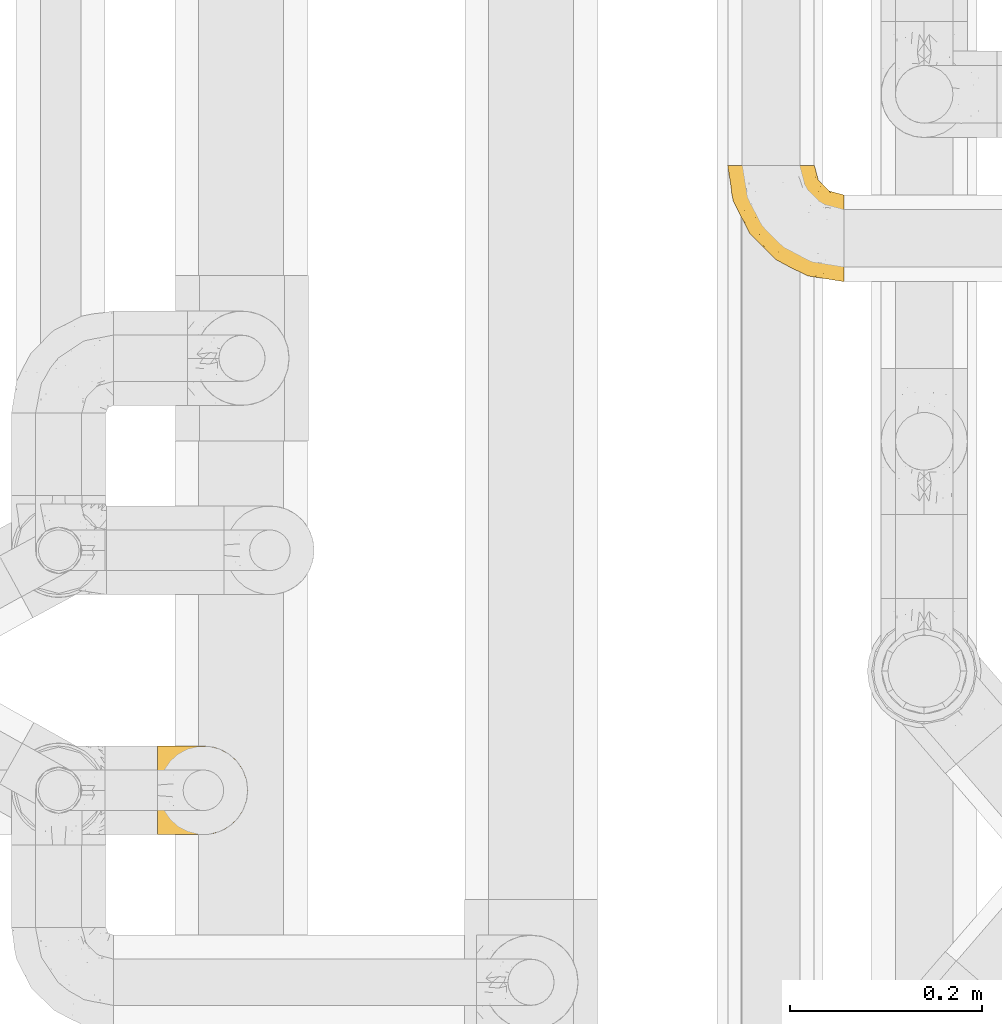
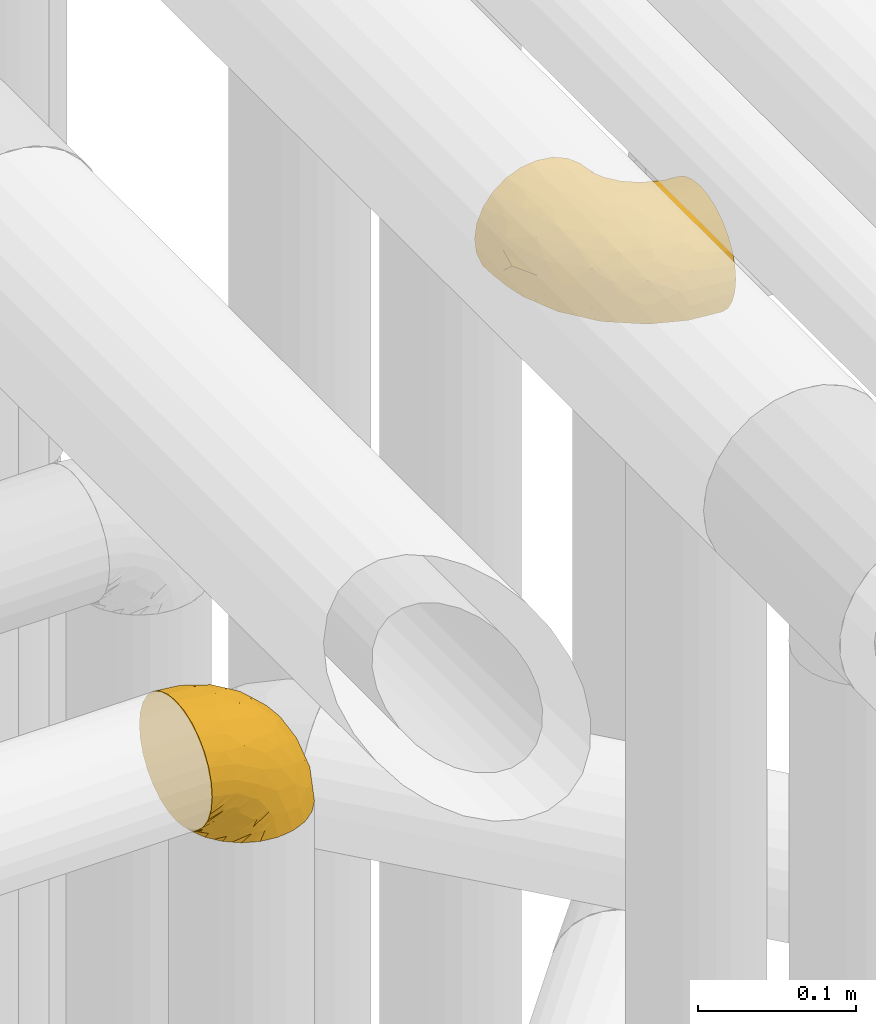
# One storey, part 201 of 827: 2 coverings.
"""IFC2X3 building model written with IfcOpenShell, lengths in millimetres."""

from ifc_helpers import new_model, entity, si_unit, converted_unit, derived_unit, direction, frame, origin, place, context, subcontext, project, spatial, faceted_brep, element, save


model = new_model("IFC2X3")

# Units and contexts
model_context = context("Model", 3, precision=0.01, world=origin(), true_north=direction((6.12303176911189e-17, 1.0)))
body_context = subcontext(model_context, "Body", "Model", "MODEL_VIEW")
ifc_project = project(units=[si_unit("LENGTHUNIT", "METRE", prefix="MILLI"), si_unit("AREAUNIT", "SQUARE_METRE"), si_unit("VOLUMEUNIT", "CUBIC_METRE"), converted_unit("PLANEANGLEUNIT", "DEGREE", entity("IfcRatioMeasure", 0.0174532925199433), si_unit("PLANEANGLEUNIT", "RADIAN"), dimensions=[0, 0, 0, 0, 0, 0, 0]), si_unit("MASSUNIT", "GRAM", prefix="KILO"), derived_unit("MASSDENSITYUNIT", [(si_unit("MASSUNIT", "GRAM", prefix="KILO"), 1), (si_unit("LENGTHUNIT", "METRE"), -3)]), derived_unit("MOMENTOFINERTIAUNIT", [(si_unit("LENGTHUNIT", "METRE"), 4)]), si_unit("TIMEUNIT", "SECOND"), si_unit("FREQUENCYUNIT", "HERTZ"), si_unit("THERMODYNAMICTEMPERATUREUNIT", "DEGREE_CELSIUS"), derived_unit("THERMALTRANSMITTANCEUNIT", [(si_unit("MASSUNIT", "GRAM", prefix="KILO"), 1), (si_unit("THERMODYNAMICTEMPERATUREUNIT", "KELVIN"), -1), (si_unit("TIMEUNIT", "SECOND"), -3)]), derived_unit("VOLUMETRICFLOWRATEUNIT", [(si_unit("LENGTHUNIT", "METRE"), 3), (si_unit("TIMEUNIT", "SECOND"), -1)]), derived_unit("MASSFLOWRATEUNIT", [(si_unit("MASSUNIT", "GRAM", prefix="KILO"), 1), (si_unit("TIMEUNIT", "SECOND"), -1)]), derived_unit("ROTATIONALFREQUENCYUNIT", [(si_unit("TIMEUNIT", "SECOND"), -1)]), si_unit("ELECTRICCURRENTUNIT", "AMPERE"), si_unit("ELECTRICVOLTAGEUNIT", "VOLT"), si_unit("POWERUNIT", "WATT"), si_unit("FORCEUNIT", "NEWTON", prefix="KILO"), si_unit("ILLUMINANCEUNIT", "LUX"), si_unit("LUMINOUSFLUXUNIT", "LUMEN"), si_unit("LUMINOUSINTENSITYUNIT", "CANDELA"), derived_unit("USERDEFINED", [(si_unit("MASSUNIT", "GRAM", prefix="KILO"), -1), (si_unit("LENGTHUNIT", "METRE"), -2), (si_unit("TIMEUNIT", "SECOND"), 3), (si_unit("LUMINOUSFLUXUNIT", "LUMEN"), 1)]), derived_unit("LINEARVELOCITYUNIT", [(si_unit("LENGTHUNIT", "METRE"), 1), (si_unit("TIMEUNIT", "SECOND"), -1)]), si_unit("PRESSUREUNIT", "PASCAL"), derived_unit("USERDEFINED", [(si_unit("LENGTHUNIT", "METRE"), -2), (si_unit("MASSUNIT", "GRAM", prefix="KILO"), 1), (si_unit("TIMEUNIT", "SECOND"), -2)]), derived_unit("LINEARFORCEUNIT", [(si_unit("MASSUNIT", "GRAM", prefix="KILO"), 1), (si_unit("LENGTHUNIT", "METRE"), 1), (si_unit("TIMEUNIT", "SECOND"), -2), (si_unit("LENGTHUNIT", "METRE"), -1)]), derived_unit("PLANARFORCEUNIT", [(si_unit("MASSUNIT", "GRAM", prefix="KILO"), 1), (si_unit("LENGTHUNIT", "METRE"), 1), (si_unit("TIMEUNIT", "SECOND"), -2), (si_unit("LENGTHUNIT", "METRE"), -2)])], contexts=[model_context])

# Site, building, storey
site_placement = place(None, origin())
site = spatial("IfcSite", under=ifc_project, at=site_placement, CompositionType="ELEMENT")
building_placement = place(site_placement, origin())
building = spatial("IfcBuilding", under=site, at=building_placement, CompositionType="ELEMENT")
storey_placement = place(building_placement, frame((0.0, 0.0, 28200.0)))
storey = spatial("IfcBuildingStorey", under=building, at=storey_placement, Name="08", CompositionType="ELEMENT", Elevation=28200.0)

# Coverings
covering_1_placement = place(storey_placement, frame((35829.19, 10308.37, 3350.4)))
element("IfcCovering", 1, at=covering_1_placement, inside=storey, Name=":ADSK_", ObjectType=":ADSK_", PredefinedType="INSULATION", context=body_context, shape_type="Brep", body=[
    faceted_brep([(1.6, 11.68, 78.41), (1.6, 19.0, 85.72), (1.6, 27.76, 91.22), (1.6, 37.52, 94.64), (1.6, 47.8, 95.8), (1.6, 58.08, 94.64), (1.6, 67.85, 91.22), (1.6, 76.61, 85.71), (1.6, 83.92, 78.39), (1.6, 89.42, 69.63), (1.6, 92.84, 59.87), (1.6, 94.0, 49.6), (1.6, 93.53, 45.45), (1.6, 93.18, 42.38), (1.6, 92.84, 39.31), (1.6, 91.13, 34.43), (1.6, 89.42, 29.54), (1.6, 86.66, 25.16), (1.6, 83.91, 20.78), (1.6, 80.25, 17.13), (1.6, 76.59, 13.47), (1.6, 67.83, 7.97), (1.6, 62.95, 6.26), (1.6, 58.07, 4.55), (1.6, 47.8, 3.4), (1.6, 37.51, 4.55), (1.6, 32.63, 6.26), (1.6, 27.74, 7.97), (1.6, 18.98, 13.48), (1.6, 15.33, 17.14), (1.6, 11.67, 20.8), (1.6, 8.92, 25.18), (1.6, 6.17, 29.56), (1.6, 4.46, 34.44), (1.6, 2.75, 39.32), (1.6, 2.41, 42.39), (1.6, 2.06, 45.45), (1.6, 1.6, 49.6), (1.6, 2.75, 59.88), (1.6, 6.17, 69.65), (3.4, 47.8, 1.6), (4.97, 59.75, 1.6), (9.58, 70.9, 1.6), (13.26, 75.68, 1.6), (16.93, 80.46, 1.6), (21.71, 84.13, 1.6), (26.5, 87.81, 1.6), (32.07, 90.11, 1.6), (37.64, 92.42, 1.6), (41.25, 92.9, 1.6), (43.34, 93.17, 1.6), (45.42, 93.45, 1.6), (49.6, 94.0, 1.6), (61.55, 92.42, 1.6), (72.7, 87.81, 1.6), (82.26, 80.46, 1.6), (89.61, 70.9, 1.6), (94.22, 59.75, 1.6), (95.8, 47.8, 1.6), (94.22, 35.84, 1.6), (89.61, 24.7, 1.6), (82.26, 15.13, 1.6), (72.7, 7.78, 1.6), (61.55, 3.17, 1.6), (49.6, 1.6, 1.6), (45.42, 2.14, 1.6), (41.25, 2.69, 1.6), (37.64, 3.17, 1.6), (32.07, 5.48, 1.6), (26.5, 7.78, 1.6), (21.71, 11.46, 1.6), (16.93, 15.13, 1.6), (13.26, 19.91, 1.6), (9.58, 24.7, 1.6), (4.97, 35.84, 1.6), (81.55, 23.61, 36.81), (90.4, 31.99, 23.28), (83.0, 35.87, 45.8), (91.18, 47.8, 30.7), (93.13, 40.43, 21.2), (94.0, 47.8, 12.96), (66.19, 31.83, 66.19), (70.92, 23.37, 54.51), (85.95, 21.41, 17.98), (49.74, 3.07, 36.69), (35.54, 1.6, 35.54), (38.14, 1.6, 31.64), (40.74, 1.6, 27.75), (43.34, 1.6, 23.86), (45.94, 1.6, 19.96), (77.59, 13.45, 22.8), (71.17, 15.25, 42.67), (65.81, 8.07, 33.21), (59.03, 16.0, 59.45), (45.85, 17.34, 71.5), (45.79, 10.58, 62.66), (41.42, 5.34, 54.5), (34.51, 2.39, 47.57), (56.04, 8.36, 48.81), (15.15, 10.04, 74.98), (56.51, 2.59, 18.7), (68.39, 6.28, 15.75), (23.33, 34.28, 91.17), (42.86, 38.73, 85.28), (39.42, 27.25, 82.58), (53.58, 29.88, 75.78), (59.17, 38.6, 74.98), (59.06, 23.44, 67.27), (22.63, 25.25, 87.38), (20.55, 17.23, 82.04), (12.96, 47.8, 94.0), (56.96, 47.8, 77.8), (67.38, 47.8, 67.38), (18.72, 2.53, 56.2), (5.33, 1.6, 48.85), (9.07, 1.6, 48.11), (11.79, 1.6, 47.57), (14.51, 1.6, 47.03), (17.24, 1.6, 46.48), (19.96, 1.6, 45.94), (21.03, 5.71, 65.78), (46.48, 1.6, 17.24), (47.03, 1.6, 14.51), (47.57, 1.6, 11.79), (48.11, 1.6, 9.07), (48.48, 1.6, 7.2), (48.85, 1.6, 5.33), (30.7, 47.8, 91.18), (23.86, 1.6, 43.34), (27.75, 1.6, 40.74), (31.64, 1.6, 38.14), (31.26, 11.89, 72.73), (77.8, 47.8, 56.96), (72.75, 39.69, 62.23), (43.83, 47.8, 84.49), (84.49, 47.8, 43.83), (14.58, 13.84, 12.05), (16.17, 9.16, 18.95), (10.82, 15.79, 13.02), (4.64, 25.75, 8.34), (7.71, 16.09, 14.63), (25.13, 7.51, 11.09), (32.66, 3.99, 13.66), (34.94, 2.66, 20.08), (36.76, 3.16, 9.61), (40.48, 2.35, 9.48), (39.25, 2.23, 16.1), (3.69, 38.35, 3.42), (13.99, 6.18, 26.63), (21.85, 2.7, 33.72), (17.93, 2.93, 34.77), (15.11, 16.01, 6.75), (21.14, 9.08, 13.31), (7.21, 11.68, 19.94), (12.7, 9.3, 21.11), (10.45, 21.65, 6.04), (32.27, 4.65, 8.67), (25.68, 3.65, 26.11), (22.18, 3.61, 29.3), (18.79, 12.8, 6.32), (10.12, 2.43, 39.92), (9.47, 6.83, 27.05), (11.29, 3.7, 34.4), (2.87, 47.8, 2.87), (31.16, 3.37, 20.92), (6.31, 7.03, 27.43), (25.62, 7.87, 7.54), (21.18, 7.26, 18.45), (28.81, 3.41, 23.88), (7.45, 23.81, 7.77), (21.17, 88.32, 18.43), (16.17, 86.42, 18.93), (25.69, 91.93, 26.08), (48.11, 94.0, 9.07), (48.85, 94.0, 5.33), (47.03, 94.0, 14.51), (47.57, 94.0, 11.79), (3.69, 57.24, 3.42), (7.44, 71.76, 7.76), (14.51, 94.0, 47.03), (11.79, 94.0, 47.57), (5.33, 94.0, 48.85), (9.07, 94.0, 48.11), (7.71, 79.49, 14.62), (9.47, 88.75, 27.03), (34.94, 92.93, 20.08), (31.16, 92.22, 20.92), (40.74, 94.0, 27.75), (38.14, 94.0, 31.64), (18.79, 82.79, 6.33), (36.76, 92.43, 9.61), (40.48, 93.24, 9.48), (4.63, 69.82, 8.33), (21.14, 86.5, 13.3), (15.11, 79.57, 6.74), (14.58, 81.74, 12.04), (43.34, 94.0, 23.86), (45.94, 94.0, 19.96), (39.25, 93.36, 16.1), (7.21, 83.9, 19.93), (12.69, 86.28, 21.1), (10.14, 93.16, 39.92), (21.81, 92.88, 33.68), (22.19, 91.98, 29.28), (14.0, 89.41, 26.62), (6.66, 88.82, 27.87), (17.92, 92.66, 34.75), (10.45, 73.93, 6.04), (31.64, 94.0, 38.14), (10.64, 79.5, 12.79), (11.31, 91.89, 34.41), (19.96, 94.0, 45.94), (23.86, 94.0, 43.34), (27.75, 94.0, 40.74), (32.66, 91.6, 13.66), (46.48, 94.0, 17.24), (32.27, 90.94, 8.67), (25.13, 88.08, 11.09), (35.54, 94.0, 35.54), (28.77, 92.16, 23.83), (23.36, 86.13, 6.03), (17.24, 94.0, 46.48), (47.58, 93.2, 34.52), (93.13, 55.16, 21.2), (77.44, 82.02, 23.82), (66.78, 84.29, 41.32), (71.68, 76.94, 47.62), (74.96, 68.33, 52.66), (81.55, 71.98, 36.81), (36.7, 92.52, 49.75), (56.9, 92.9, 19.07), (83.0, 59.72, 45.8), (90.4, 63.6, 23.28), (67.83, 88.89, 21.35), (85.95, 74.18, 17.98), (39.41, 68.35, 82.57), (23.33, 61.33, 91.17), (42.87, 56.86, 85.27), (53.92, 68.62, 73.89), (66.19, 63.76, 66.19), (64.12, 72.19, 62.43), (33.13, 88.69, 63.53), (23.1, 92.19, 58.45), (16.98, 89.75, 67.16), (55.72, 59.86, 76.72), (72.75, 55.9, 62.22), (23.77, 77.99, 81.54), (18.41, 85.21, 74.8), (43.7, 74.99, 75.83), (54.53, 90.23, 41.45), (17.73, 70.75, 88.2), (38.98, 81.72, 71.6), (50.28, 86.53, 56.23), (59.02, 79.6, 59.44)], [[[0, 1, 2, 3, 4, 5, 6, 7, 8, 9, 10, 11, 12, 13, 14, 15, 16, 17, 18, 19, 20, 21, 22, 23, 24, 25, 26, 27, 28, 29, 30, 31, 32, 33, 34, 35, 36, 37, 38, 39]], [[40, 41, 42, 43, 44, 45, 46, 47, 48, 49, 50, 51, 52, 53, 54, 55, 56, 57, 58, 59, 60, 61, 62, 63, 64, 65, 66, 67, 68, 69, 70, 71, 72, 73, 74]], [[75, 76, 77]], [[78, 79, 80]], [[77, 81, 82]], [[76, 75, 83]], [[84, 85, 86, 87, 88, 89]], [[90, 91, 92]], [[76, 60, 59]], [[93, 94, 95]], [[90, 62, 61]], [[83, 61, 60]], [[96, 97, 84]], [[98, 93, 95]], [[0, 39, 99]], [[100, 84, 89]], [[62, 101, 63]], [[2, 102, 3]], [[92, 84, 100]], [[103, 102, 104]], [[103, 105, 106]], [[93, 107, 94]], [[1, 108, 2]], [[92, 101, 90]], [[108, 1, 109]], [[102, 110, 3]], [[93, 82, 107]], [[102, 108, 104]], [[111, 106, 112]], [[109, 0, 99]], [[113, 37, 114, 115, 116, 117, 118, 119]], [[120, 38, 113]], [[100, 89, 121, 122, 123, 124, 125, 126, 64]], [[127, 102, 103]], [[97, 119, 128, 129, 130, 85]], [[99, 120, 131]], [[132, 133, 77]], [[59, 80, 79]], [[1, 0, 109]], [[98, 84, 92]], [[94, 109, 131]], [[120, 39, 38]], [[93, 91, 82]], [[104, 94, 105]], [[97, 113, 119]], [[95, 120, 96]], [[83, 90, 61]], [[91, 93, 98]], [[64, 63, 100]], [[100, 63, 101]], [[77, 76, 79]], [[133, 106, 81]], [[84, 97, 85]], [[113, 96, 120]], [[113, 97, 96]], [[37, 113, 38]], [[110, 102, 127]], [[110, 4, 3]], [[103, 111, 134, 127]], [[90, 75, 91]], [[82, 81, 107]], [[91, 75, 82]], [[77, 82, 75]], [[76, 83, 60]], [[90, 83, 75]], [[105, 107, 81]], [[94, 131, 95]], [[105, 94, 107]], [[109, 94, 104]], [[120, 95, 131]], [[98, 95, 96]], [[84, 98, 96]], [[98, 92, 91]], [[106, 105, 81]], [[103, 104, 105]], [[112, 106, 133]], [[103, 106, 111]], [[112, 133, 132]], [[81, 77, 133]], [[77, 78, 135, 132]], [[120, 99, 39]], [[109, 99, 131]], [[59, 58, 80]], [[59, 79, 76]], [[90, 101, 62]], [[100, 101, 92]], [[2, 108, 102]], [[109, 104, 108]], [[78, 77, 79]], [[136, 137, 138]], [[27, 139, 140]], [[141, 142, 143]], [[144, 145, 121]], [[146, 89, 88]], [[147, 139, 25]], [[148, 149, 150]], [[136, 151, 152]], [[147, 40, 74]], [[24, 147, 25]], [[153, 140, 154]], [[33, 116, 34]], [[73, 151, 155]], [[114, 37, 36, 35, 34, 116, 115]], [[146, 156, 144]], [[157, 85, 130]], [[158, 149, 148]], [[151, 159, 152]], [[117, 33, 160]], [[29, 153, 161]], [[155, 74, 73]], [[162, 128, 119]], [[66, 65, 64, 126, 125, 124, 123, 122, 67]], [[163, 147, 24]], [[27, 140, 28]], [[149, 129, 150]], [[139, 27, 26, 25]], [[68, 144, 69]], [[129, 128, 150]], [[164, 87, 86]], [[130, 129, 149]], [[122, 145, 67]], [[153, 154, 148]], [[162, 119, 160]], [[165, 30, 161]], [[150, 161, 148]], [[128, 162, 150]], [[30, 165, 31]], [[145, 144, 68]], [[89, 146, 144]], [[87, 164, 143]], [[166, 156, 142]], [[88, 87, 143]], [[162, 161, 150]], [[161, 30, 29]], [[161, 153, 148]], [[28, 140, 153]], [[29, 28, 153]], [[140, 137, 154]], [[158, 148, 154]], [[157, 130, 158]], [[154, 137, 158]], [[158, 137, 157]], [[167, 137, 136]], [[168, 85, 157]], [[152, 168, 167]], [[167, 168, 157]], [[164, 152, 141]], [[151, 73, 72]], [[159, 72, 71]], [[88, 142, 146]], [[144, 156, 69]], [[146, 142, 156]], [[70, 166, 71]], [[142, 141, 166]], [[70, 69, 156]], [[141, 159, 71]], [[167, 136, 152]], [[138, 137, 140]], [[155, 136, 169]], [[136, 155, 151]], [[74, 155, 169]], [[152, 159, 141]], [[151, 72, 159]], [[168, 152, 164]], [[137, 167, 157]], [[164, 86, 168]], [[85, 168, 86]], [[116, 33, 117]], [[130, 149, 158]], [[67, 145, 68]], [[121, 89, 144]], [[145, 122, 121]], [[40, 147, 163]], [[169, 147, 74]], [[160, 33, 32]], [[162, 160, 32]], [[160, 119, 118, 117]], [[139, 147, 169]], [[139, 169, 138]], [[162, 32, 31]], [[141, 143, 164]], [[88, 143, 142]], [[71, 166, 141]], [[156, 166, 70]], [[139, 138, 140]], [[169, 136, 138]], [[161, 162, 165]], [[162, 31, 165]], [[170, 171, 172]], [[173, 174, 52, 51, 50, 49, 48, 175, 176]], [[177, 178, 41]], [[179, 15, 180]], [[12, 11, 181, 182, 180, 14, 13]], [[183, 21, 20]], [[19, 18, 184]], [[185, 186, 187]], [[186, 188, 187]], [[43, 189, 44]], [[190, 191, 47]], [[23, 22, 21, 192]], [[193, 194, 195]], [[40, 163, 177]], [[196, 197, 198]], [[24, 23, 177]], [[199, 200, 183]], [[201, 15, 179]], [[178, 177, 192]], [[47, 46, 190]], [[202, 203, 204]], [[203, 172, 171]], [[205, 206, 184]], [[207, 41, 178]], [[16, 15, 201]], [[14, 180, 15]], [[204, 203, 200]], [[208, 203, 202]], [[163, 24, 177]], [[48, 47, 191]], [[198, 197, 190]], [[199, 184, 204]], [[171, 195, 209]], [[210, 211, 212]], [[206, 212, 213]], [[205, 17, 210]], [[184, 206, 204]], [[210, 212, 206]], [[185, 196, 214]], [[190, 215, 191]], [[216, 45, 214]], [[186, 217, 193]], [[190, 216, 198]], [[199, 20, 19]], [[196, 185, 187]], [[199, 183, 20]], [[184, 199, 19]], [[199, 204, 200]], [[206, 202, 204]], [[171, 183, 200]], [[203, 208, 172]], [[172, 208, 218]], [[171, 200, 203]], [[218, 188, 219]], [[195, 170, 193]], [[217, 186, 185]], [[193, 219, 186]], [[193, 170, 219]], [[207, 194, 42]], [[217, 220, 189]], [[216, 190, 46]], [[214, 196, 198]], [[44, 220, 45]], [[214, 198, 216]], [[216, 46, 45]], [[214, 45, 220]], [[42, 194, 43]], [[189, 193, 217]], [[207, 195, 194]], [[209, 195, 178]], [[41, 207, 42]], [[195, 207, 178]], [[43, 194, 189]], [[193, 189, 194]], [[171, 170, 195]], [[170, 172, 219]], [[218, 219, 172]], [[188, 186, 219]], [[206, 213, 202]], [[208, 202, 213]], [[201, 210, 16]], [[215, 190, 197]], [[215, 175, 191]], [[175, 48, 191]], [[201, 179, 221, 211]], [[210, 201, 211]], [[23, 192, 177]], [[40, 177, 41]], [[192, 183, 209]], [[21, 183, 192]], [[205, 18, 17]], [[17, 16, 210]], [[217, 185, 214]], [[189, 220, 44]], [[214, 220, 217]], [[192, 209, 178]], [[171, 209, 183]], [[206, 205, 210]], [[18, 205, 184]], [[222, 197, 196, 187, 188, 218]], [[57, 223, 80]], [[224, 225, 226]], [[226, 227, 228]], [[229, 218, 208, 213, 212, 211]], [[230, 52, 174, 173, 176, 175, 215, 197]], [[231, 232, 228]], [[231, 78, 223]], [[223, 57, 232]], [[224, 233, 225]], [[233, 54, 53]], [[234, 232, 56]], [[56, 55, 234]], [[234, 224, 228]], [[235, 236, 237]], [[224, 55, 54]], [[238, 239, 240]], [[52, 230, 53]], [[241, 242, 243]], [[239, 244, 245]], [[11, 10, 242]], [[236, 6, 5]], [[7, 246, 8]], [[8, 247, 9]], [[238, 248, 235]], [[222, 229, 249]], [[242, 211, 221, 179, 180, 182, 181, 11]], [[233, 53, 230]], [[111, 112, 244]], [[250, 6, 236]], [[247, 251, 241]], [[6, 250, 7]], [[127, 236, 110]], [[249, 229, 252]], [[247, 8, 246]], [[235, 246, 250]], [[236, 5, 110]], [[235, 244, 238]], [[237, 236, 127]], [[243, 9, 247]], [[252, 229, 241]], [[56, 232, 57]], [[222, 230, 197]], [[225, 249, 252]], [[249, 233, 230]], [[54, 233, 224]], [[231, 228, 227]], [[245, 132, 231]], [[249, 225, 233]], [[226, 225, 253]], [[235, 250, 236]], [[246, 7, 250]], [[251, 247, 246]], [[243, 247, 241]], [[248, 246, 235]], [[252, 251, 253]], [[229, 222, 218]], [[230, 222, 249]], [[5, 4, 110]], [[237, 127, 134, 111]], [[238, 244, 239]], [[224, 234, 55]], [[232, 234, 228]], [[242, 241, 229]], [[10, 9, 243]], [[211, 242, 229]], [[10, 243, 242]], [[80, 223, 78]], [[80, 58, 57]], [[231, 223, 232]], [[227, 240, 239]], [[224, 226, 228]], [[240, 226, 253]], [[227, 239, 245]], [[226, 240, 227]], [[251, 248, 253]], [[240, 253, 248]], [[244, 235, 237]], [[237, 111, 244]], [[132, 245, 112]], [[112, 245, 244]], [[135, 78, 231, 132]], [[227, 245, 231]], [[248, 238, 240]], [[246, 248, 251]], [[251, 252, 241]], [[225, 252, 253]]]),
])
covering_2_placement = place(storey_placement, frame((36423.29, 10884.43, 3153.25)))
element("IfcCovering", 2, at=covering_2_placement, inside=storey, Name=":ADSK_", ObjectType=":ADSK_", PredefinedType="INSULATION", context=body_context, shape_type="Brep", body=[
    faceted_brep([(122.75, 36.69, 90.76), (122.75, 27.15, 87.42), (122.75, 18.59, 82.04), (122.75, 11.44, 74.89), (122.75, 6.06, 66.33), (122.75, 2.73, 56.79), (122.75, 1.6, 46.75), (122.75, 2.73, 36.69), (122.75, 6.07, 27.15), (122.75, 11.45, 18.59), (122.75, 18.6, 11.44), (122.75, 27.16, 6.06), (122.75, 36.7, 2.73), (122.75, 46.75, 1.6), (122.75, 56.8, 2.73), (122.75, 66.34, 6.07), (122.75, 74.9, 11.45), (122.75, 82.05, 18.6), (122.75, 87.43, 27.16), (122.75, 90.76, 36.7), (122.75, 91.9, 46.75), (122.75, 90.76, 56.8), (122.75, 87.42, 66.34), (122.75, 82.04, 74.9), (122.75, 74.89, 82.05), (122.75, 66.33, 87.43), (122.75, 56.79, 90.76), (122.75, 46.75, 91.9), (90.36, 122.75, 35.06), (85.85, 122.75, 24.17), (78.67, 122.75, 14.82), (69.32, 122.75, 7.64), (58.43, 122.75, 3.13), (46.75, 122.75, 1.6), (35.06, 122.75, 3.13), (24.17, 122.75, 7.64), (14.82, 122.75, 14.82), (7.64, 122.75, 24.17), (3.13, 122.75, 35.06), (1.6, 122.75, 46.75), (3.13, 122.75, 58.43), (7.64, 122.75, 69.32), (14.82, 122.75, 78.67), (24.17, 122.75, 85.85), (35.06, 122.75, 90.36), (46.75, 122.75, 91.9), (58.43, 122.75, 90.36), (69.32, 122.75, 85.85), (78.67, 122.75, 78.67), (85.85, 122.75, 69.32), (90.36, 122.75, 58.43), (91.9, 122.75, 46.75), (51.54, 24.73, 46.75), (47.17, 29.08, 55.2), (38.13, 38.13, 46.75), (7.52, 85.31, 46.75), (5.85, 93.59, 54.53), (5.11, 100.54, 46.75), (19.2, 63.54, 59.63), (38.98, 38.98, 62.07), (35.02, 50.71, 71.86), (8.21, 93.33, 62.65), (19.28, 75.2, 71.33), (12.19, 100.46, 72.93), (101.39, 41.6, 91.2), (34.43, 80.86, 86.31), (20.95, 94.87, 80.89), (30.74, 67.96, 79.49), (72.93, 52.16, 90.68), (56.64, 52.1, 86.84), (80.81, 36.74, 87.38), (93.43, 17.11, 76.87), (100.76, 23.24, 83.73), (74.27, 29.18, 81.03), (93.66, 52.53, 91.9), (81.33, 60.77, 91.9), (69.01, 69.01, 91.9), (40.87, 100.68, 91.03), (29.38, 103.79, 87.58), (67.05, 16.37, 56.52), (85.31, 7.52, 46.75), (93.68, 7.31, 60.4), (52.53, 93.66, 91.9), (50.71, 102.83, 91.9), (48.88, 112.01, 91.9), (72.77, 18.17, 67.87), (51.21, 71.97, 90.35), (101.18, 9.83, 69.57), (100.54, 5.11, 46.75), (48.74, 45.97, 79.91), (112.01, 48.88, 91.9), (102.83, 50.71, 91.9), (73.88, 22.83, 74.99), (24.73, 51.54, 46.75), (60.77, 81.33, 91.9), (103.08, 31.74, 88.53), (54.8, 32.48, 72.65), (16.13, 68.42, 46.75), (55.92, 25.33, 62.97), (68.42, 16.13, 46.75), (104.98, 92.29, 66.2), (108.58, 94.12, 56.6), (98.21, 100.97, 59.89), (61.56, 95.91, 90.95), (60.69, 107.9, 90.22), (100.0, 87.24, 76.64), (95.88, 95.46, 71.58), (90.81, 90.41, 79.99), (84.88, 74.17, 89.54), (73.29, 83.77, 89.97), (113.4, 76.72, 81.32), (109.8, 84.44, 74.56), (102.13, 76.42, 84.15), (67.29, 90.07, 90.37), (70.34, 99.69, 87.82), (95.15, 61.74, 90.98), (105.49, 58.16, 90.96), (71.5, 112.6, 85.14), (92.87, 110.45, 58.11), (96.03, 107.32, 46.75), (81.34, 108.48, 78.39), (107.44, 66.63, 88.22), (88.36, 115.23, 66.06), (90.43, 105.79, 68.6), (114.37, 89.6, 63.78), (98.41, 69.39, 88.42), (88.73, 66.99, 90.61), (76.89, 102.31, 83.8), (86.08, 99.54, 77.98), (112.64, 55.27, 91.22), (94.21, 82.03, 83.46), (112.22, 94.71, 46.75), (107.32, 96.03, 46.75), (79.95, 94.11, 84.66), (84.51, 84.21, 86.33), (101.67, 101.67, 46.75), (94.71, 112.22, 46.75), (81.34, 108.48, 15.1), (76.89, 102.31, 9.69), (86.08, 99.54, 15.52), (79.96, 94.11, 8.83), (92.87, 110.46, 35.39), (113.41, 76.74, 12.18), (102.83, 50.71, 1.6), (105.5, 58.17, 2.53), (112.64, 55.27, 2.27), (108.58, 94.12, 36.9), (104.98, 92.3, 27.31), (98.2, 100.98, 33.62), (98.4, 69.41, 5.07), (102.13, 76.44, 9.36), (107.44, 66.65, 5.27), (88.36, 115.24, 27.43), (50.71, 102.83, 1.6), (48.88, 112.01, 1.6), (94.22, 82.05, 10.05), (100.01, 87.25, 16.87), (71.5, 112.6, 8.35), (60.69, 107.9, 3.27), (52.53, 93.66, 1.6), (95.89, 95.48, 21.94), (114.37, 89.6, 29.72), (81.33, 60.77, 1.6), (69.01, 69.01, 1.6), (84.88, 74.17, 3.96), (112.01, 48.88, 1.6), (109.8, 84.45, 18.95), (61.56, 95.91, 2.54), (67.29, 90.07, 3.12), (60.77, 81.33, 1.6), (95.14, 61.75, 2.51), (73.29, 83.77, 3.52), (84.53, 84.21, 7.17), (93.66, 52.53, 1.6), (90.82, 90.42, 13.52), (88.73, 67.0, 2.88), (70.34, 99.69, 5.67), (90.43, 105.8, 24.89), (20.95, 94.87, 12.6), (34.43, 80.86, 7.18), (30.74, 67.95, 14.0), (19.29, 75.17, 22.16), (35.07, 50.65, 21.61), (51.21, 71.97, 3.14), (56.67, 52.08, 6.65), (54.85, 32.46, 20.82), (38.98, 38.98, 31.41), (29.38, 103.79, 5.91), (40.87, 100.68, 2.46), (19.2, 63.54, 33.87), (8.21, 93.32, 30.84), (5.85, 93.59, 38.96), (12.19, 100.44, 20.56), (72.93, 52.17, 2.81), (80.83, 36.75, 6.1), (101.39, 41.61, 2.29), (93.69, 7.31, 33.08), (93.43, 17.12, 16.61), (67.04, 16.37, 36.96), (100.76, 23.26, 9.75), (72.78, 18.17, 25.61), (55.93, 25.33, 30.5), (101.18, 9.84, 23.91), (74.27, 29.19, 12.45), (73.89, 22.84, 18.49), (103.09, 31.75, 4.96), (48.78, 45.96, 13.56), (47.19, 29.07, 38.28)], [[[0, 1, 2, 3, 4, 5, 6, 7, 8, 9, 10, 11, 12, 13, 14, 15, 16, 17, 18, 19, 20, 21, 22, 23, 24, 25, 26, 27]], [[28, 29, 30, 31, 32, 33, 34, 35, 36, 37, 38, 39, 40, 41, 42, 43, 44, 45, 46, 47, 48, 49, 50, 51]], [[52, 53, 54]], [[55, 56, 57]], [[58, 59, 60]], [[61, 62, 63]], [[27, 64, 0]], [[65, 66, 67]], [[41, 40, 61]], [[68, 69, 70]], [[66, 43, 42]], [[63, 42, 41]], [[71, 72, 73]], [[72, 2, 1]], [[68, 74, 75, 76]], [[45, 44, 77]], [[43, 78, 44]], [[79, 80, 81]], [[77, 82, 83, 84, 45]], [[79, 81, 85]], [[71, 2, 72]], [[65, 86, 77]], [[4, 81, 5]], [[66, 65, 78]], [[4, 3, 87]], [[81, 88, 5]], [[63, 66, 42]], [[68, 70, 64]], [[67, 60, 89]], [[71, 3, 2]], [[64, 27, 90, 91, 74]], [[92, 71, 73]], [[40, 57, 56]], [[59, 93, 54]], [[86, 76, 94, 82]], [[1, 0, 95]], [[58, 62, 61]], [[60, 96, 89]], [[85, 81, 87]], [[56, 97, 58]], [[65, 67, 69]], [[87, 81, 4]], [[67, 89, 69]], [[61, 63, 41]], [[95, 72, 1]], [[73, 72, 70]], [[69, 73, 70]], [[73, 89, 96]], [[3, 71, 87]], [[85, 87, 71]], [[58, 61, 56]], [[59, 58, 93]], [[76, 86, 68]], [[69, 89, 73]], [[68, 86, 69]], [[65, 69, 86]], [[68, 64, 74]], [[95, 64, 70]], [[98, 79, 85]], [[79, 52, 99, 80]], [[66, 62, 67]], [[62, 58, 60]], [[62, 60, 67]], [[59, 98, 96]], [[59, 96, 60]], [[96, 85, 92]], [[88, 81, 80]], [[88, 6, 5]], [[66, 63, 62]], [[64, 95, 0]], [[72, 95, 70]], [[77, 44, 78]], [[86, 82, 77]], [[40, 39, 57]], [[96, 98, 85]], [[40, 56, 61]], [[66, 78, 43]], [[77, 78, 65]], [[79, 98, 53]], [[96, 92, 73]], [[85, 71, 92]], [[97, 56, 55]], [[97, 93, 58]], [[53, 98, 59]], [[54, 53, 59]], [[79, 53, 52]], [[100, 101, 102]], [[46, 45, 84, 83]], [[103, 104, 82]], [[82, 104, 83]], [[105, 106, 107]], [[108, 109, 76]], [[110, 111, 112]], [[103, 113, 114]], [[115, 74, 116]], [[48, 47, 117]], [[118, 102, 119]], [[49, 48, 120]], [[74, 91, 116]], [[116, 121, 115]], [[49, 122, 50]], [[123, 106, 102]], [[124, 111, 22]], [[125, 126, 115]], [[23, 22, 111]], [[24, 110, 121]], [[120, 127, 128]], [[90, 26, 129]], [[27, 26, 90]], [[121, 125, 115]], [[24, 121, 25]], [[130, 105, 107]], [[129, 25, 116]], [[21, 20, 131]], [[120, 123, 122]], [[112, 105, 130]], [[50, 118, 51]], [[21, 124, 22]], [[101, 131, 132]], [[117, 120, 48]], [[24, 23, 110]], [[127, 114, 133]], [[75, 108, 76]], [[107, 134, 130]], [[133, 114, 113]], [[129, 116, 91]], [[25, 121, 116]], [[121, 112, 125]], [[75, 74, 115]], [[101, 135, 102]], [[131, 101, 21]], [[101, 100, 124]], [[128, 127, 133]], [[119, 136, 51, 118]], [[104, 47, 46]], [[83, 104, 46]], [[117, 104, 114]], [[101, 124, 21]], [[111, 124, 100]], [[102, 118, 123]], [[133, 134, 107]], [[111, 110, 23]], [[114, 104, 103]], [[94, 76, 109]], [[121, 110, 112]], [[122, 118, 50]], [[134, 109, 108]], [[133, 107, 128]], [[112, 108, 125]], [[126, 125, 108]], [[108, 75, 126]], [[75, 115, 126]], [[109, 134, 133]], [[130, 108, 112]], [[108, 130, 134]], [[105, 112, 111]], [[111, 100, 105]], [[106, 105, 100]], [[102, 106, 100]], [[128, 106, 123]], [[90, 129, 91]], [[25, 129, 26]], [[104, 117, 47]], [[117, 114, 127]], [[82, 94, 103]], [[113, 94, 109]], [[94, 113, 103]], [[133, 113, 109]], [[106, 128, 107]], [[123, 120, 128]], [[120, 122, 49]], [[118, 122, 123]], [[135, 101, 132]], [[135, 119, 102]], [[117, 127, 120]], [[30, 29, 137]], [[138, 139, 140]], [[51, 136, 119, 141]], [[142, 17, 16]], [[143, 144, 145]], [[146, 147, 148]], [[149, 150, 151]], [[152, 29, 28]], [[33, 32, 153, 154]], [[150, 155, 156]], [[157, 31, 30]], [[153, 158, 159]], [[29, 152, 137]], [[148, 141, 119]], [[156, 160, 147]], [[148, 135, 146]], [[137, 138, 157]], [[19, 161, 146]], [[162, 163, 164]], [[14, 13, 165]], [[153, 32, 158]], [[147, 161, 166]], [[18, 17, 166]], [[167, 168, 169]], [[166, 150, 156]], [[151, 150, 142]], [[151, 170, 149]], [[151, 16, 15]], [[171, 140, 172]], [[165, 143, 145]], [[173, 170, 144]], [[142, 166, 17]], [[19, 131, 20]], [[144, 170, 151]], [[18, 161, 19]], [[173, 144, 143]], [[140, 139, 174]], [[171, 164, 163]], [[164, 172, 155]], [[151, 15, 144]], [[145, 15, 14]], [[173, 162, 170]], [[149, 175, 164]], [[19, 146, 131]], [[132, 131, 146]], [[160, 148, 147]], [[159, 158, 167]], [[135, 132, 146]], [[158, 32, 31]], [[157, 158, 31]], [[167, 158, 176]], [[166, 161, 18]], [[146, 161, 147]], [[148, 177, 141]], [[171, 168, 140]], [[171, 163, 169]], [[151, 142, 16]], [[166, 142, 150]], [[152, 141, 177]], [[51, 141, 28]], [[138, 140, 176]], [[172, 140, 174]], [[175, 149, 170]], [[164, 150, 149]], [[170, 162, 175]], [[162, 164, 175]], [[155, 172, 174]], [[171, 172, 164]], [[155, 174, 156]], [[164, 155, 150]], [[160, 156, 174]], [[147, 166, 156]], [[139, 160, 174]], [[148, 160, 177]], [[15, 145, 144]], [[165, 145, 14]], [[137, 157, 30]], [[158, 157, 176]], [[168, 167, 176]], [[169, 159, 167]], [[140, 168, 176]], [[169, 168, 171]], [[137, 177, 139]], [[160, 139, 177]], [[141, 152, 28]], [[137, 152, 177]], [[148, 119, 135]], [[157, 138, 176]], [[139, 138, 137]], [[178, 179, 180]], [[181, 180, 182]], [[179, 183, 184]], [[185, 186, 182]], [[187, 188, 179]], [[188, 33, 154, 153, 159]], [[181, 189, 190]], [[35, 34, 187]], [[191, 38, 190]], [[192, 178, 181]], [[179, 184, 180]], [[192, 190, 37]], [[37, 190, 38]], [[36, 35, 178]], [[54, 93, 186]], [[35, 187, 178]], [[193, 194, 184]], [[195, 173, 143, 165, 13]], [[195, 193, 173]], [[193, 163, 162, 173]], [[13, 12, 195]], [[8, 7, 196]], [[9, 197, 10]], [[198, 80, 99, 52]], [[196, 7, 88]], [[197, 199, 10]], [[182, 189, 181]], [[200, 198, 201]], [[200, 196, 198]], [[9, 8, 202]], [[194, 199, 203]], [[192, 37, 36]], [[80, 196, 88]], [[183, 159, 169, 163]], [[188, 34, 33]], [[202, 200, 197]], [[185, 203, 204]], [[202, 8, 196]], [[10, 199, 11]], [[12, 11, 205]], [[38, 191, 57]], [[189, 97, 191]], [[203, 199, 197]], [[205, 199, 194]], [[204, 203, 197]], [[184, 203, 206]], [[200, 202, 196]], [[197, 9, 202]], [[207, 54, 186]], [[97, 55, 191]], [[194, 203, 184]], [[183, 163, 193]], [[184, 206, 180]], [[183, 193, 184]], [[205, 195, 12]], [[193, 195, 194]], [[80, 198, 196]], [[207, 186, 201]], [[182, 180, 206]], [[181, 178, 180]], [[185, 182, 206]], [[182, 186, 189]], [[203, 185, 206]], [[185, 200, 201]], [[7, 6, 88]], [[178, 192, 36]], [[190, 192, 181]], [[199, 205, 11]], [[195, 205, 194]], [[159, 183, 188]], [[179, 188, 183]], [[57, 191, 55]], [[57, 39, 38]], [[189, 191, 190]], [[188, 187, 34]], [[178, 187, 179]], [[186, 93, 189]], [[197, 200, 204]], [[185, 204, 200]], [[189, 93, 97]], [[207, 198, 52]], [[185, 201, 186]], [[198, 207, 201]], [[54, 207, 52]]]),
])

save(model, "model.ifc")
